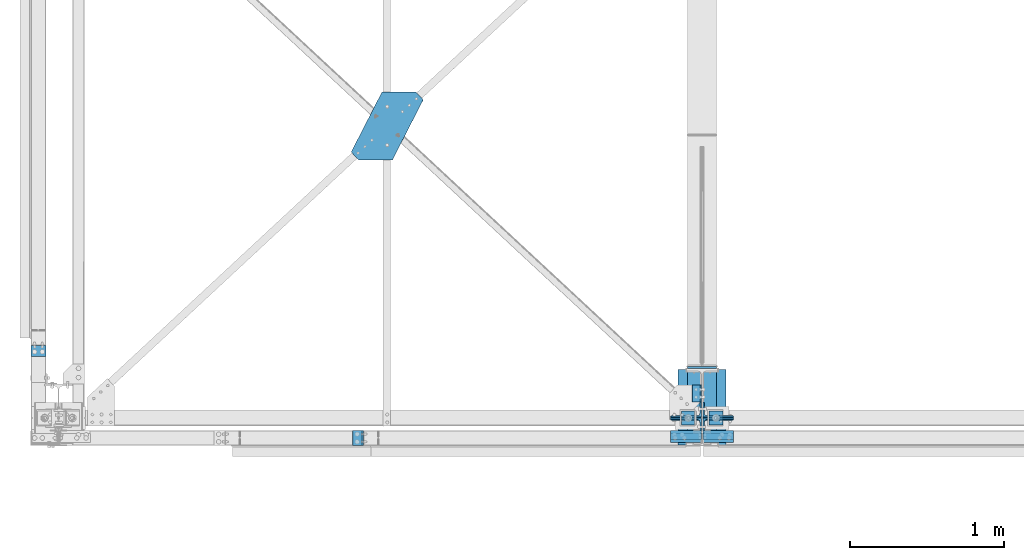
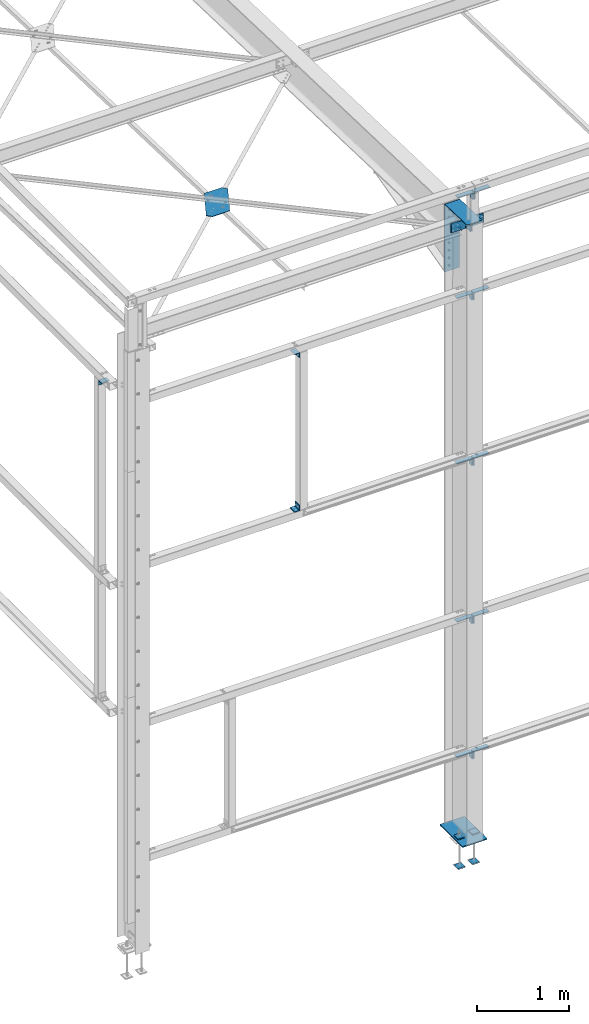
# One storey, part 62 of 496: 23 beams, 4 members, 23 elements without a shape of their own.
"""IFC2X3 building model written with IfcOpenShell, lengths in millimetres."""

import ifcopenshell
import ifcopenshell.guid

model = None  # the IFC model being written
_history = None  # IfcOwnerHistory: only IFC2X3 demands one
_inside = {}  # id of a spatial element -> (the spatial element, [elements in it])
_under = {}  # id of a project, library or spatial element -> (it, [spatial elements below it])
_declared = {}  # id of a project -> (the project, [libraries it declares])
_typed = {}  # id of a type object -> (the type object, [elements of that type])
_made_of = {}  # id of a material, layer set ... -> (it, [elements and type objects made of it])


def new_model(schema):
    """Start an empty IFC model of exactly this schema.

    Asked for "IFC4X3", IfcOpenShell would pick the latest addendum, in which some entities
    have other attributes; the version numbers below select the first issue.
    IFC2X3 requires an IfcOwnerHistory on every rooted entity: one is made here for all.
    """
    global model, _history
    if schema == "IFC4X3":
        model = ifcopenshell.file(schema_version=(4, 3, 0, 0))
    else:
        model = ifcopenshell.file(schema=schema)
    _inside.clear()
    _under.clear()
    _declared.clear()
    _typed.clear()
    _made_of.clear()
    _history = None
    if model.schema == "IFC2X3":
        org = make("IfcOrganization", Name="unknown")
        user = make(
            "IfcPersonAndOrganization",
            ThePerson=make("IfcPerson", FamilyName="unknown"),
            TheOrganization=org,
        )
        app = make(
            "IfcApplication",
            ApplicationDeveloper=org,
            Version="unknown",
            ApplicationFullName="unknown",
            ApplicationIdentifier="unknown",
        )
        _history = make(
            "IfcOwnerHistory",
            OwningUser=user,
            OwningApplication=app,
            ChangeAction="ADDED",
            CreationDate=0,
        )
    return model


def make(cls, **values):
    """One entity of the class cls with the attributes given. An attribute that is None is left unset."""
    return model.create_entity(
        cls, **{name: value for name, value in values.items() if value is not None}
    )


def rooted(cls, **values):
    """An entity with a GlobalId (a new one), such as an element, a storey or a relation."""
    return make(cls, GlobalId=ifcopenshell.guid.new(), OwnerHistory=_history, **values)


def si_unit(unit_type, name, prefix=None):
    """IfcSIUnit, for example si_unit("LENGTHUNIT", "METRE", prefix="MILLI")."""
    return make("IfcSIUnit", UnitType=unit_type, Prefix=prefix, Name=name)


def assignment(units):
    """IfcUnitAssignment: the units of a project."""
    return None if units is None else make("IfcUnitAssignment", Units=units)


def point(xyz):
    """IfcCartesianPoint."""
    return None if xyz is None else make("IfcCartesianPoint", Coordinates=xyz)


def direction(xyz):
    """IfcDirection."""
    return None if xyz is None else make("IfcDirection", DirectionRatios=xyz)


def frame(location, z_axis=None, x_axis=None):
    """IfcAxis2Placement3D, a coordinate frame: its origin and axes. An axis left out is left unset."""
    return make(
        "IfcAxis2Placement3D",
        Location=point(location),
        Axis=direction(z_axis),
        RefDirection=direction(x_axis),
    )


def frame_2d(location, x_axis=None):
    """IfcAxis2Placement2D, a coordinate frame in the plane: its origin and x axis."""
    return make(
        "IfcAxis2Placement2D", Location=point(location), RefDirection=direction(x_axis)
    )


def origin_with_axes():
    """The frame at (0, 0, 0) with the z axis (0, 0, 1) and the x axis (1, 0, 0) written out."""
    return frame((0.0, 0.0, 0.0), z_axis=(0.0, 0.0, 1.0), x_axis=(1.0, 0.0, 0.0))


def origin_2d_with_axis():
    """The frame at (0, 0) in the plane with the x axis (1, 0) written out."""
    return frame_2d((0.0, 0.0), x_axis=(1.0, 0.0))


def place(relative_to, where):
    """IfcLocalPlacement: puts the frame where relative to a parent placement (None: the world)."""
    return make(
        "IfcLocalPlacement", PlacementRelTo=relative_to, RelativePlacement=where
    )


def context(
    kind, dimensions, precision=None, world=None, true_north=None, identifier=None
):
    """IfcGeometricRepresentationContext, for example the 3D "Model" context."""
    return make(
        "IfcGeometricRepresentationContext",
        ContextIdentifier=identifier,
        ContextType=kind,
        CoordinateSpaceDimension=dimensions,
        Precision=precision,
        WorldCoordinateSystem=world,
        TrueNorth=true_north,
    )


def subcontext(parent, identifier, kind, view, scale=None):
    """IfcGeometricRepresentationSubContext, for example "Body" below "Model"."""
    return make(
        "IfcGeometricRepresentationSubContext",
        ContextIdentifier=identifier,
        ContextType=kind,
        ParentContext=parent,
        TargetScale=scale,
        TargetView=view,
    )


def project(units=None, contexts=None):
    """IfcProject with its units and contexts."""
    return rooted(
        "IfcProject",
        Name="project",
        RepresentationContexts=contexts,
        UnitsInContext=assignment(units),
    )


def spatial(cls, under=None, at=None, **own):
    """A site, building, storey or space (cls), placed at a placement, below another one or the project."""
    s = rooted(cls, ObjectPlacement=at, **own)
    if under is not None:
        _under.setdefault(under.id(), (under, []))[1].append(s)
    return s


def polyline(points):
    """IfcPolyline through the points."""
    return make("IfcPolyline", Points=[point(p) for p in points])


def profile(cls, at=None, kind="AREA", **sizes):
    """A parametric profile (cls). Its sizes go by their IFC names, for example OverallWidth=200.0."""
    return make(cls, ProfileType=kind, Position=at, **sizes)


def rectangle(**sizes):
    """IfcRectangleProfileDef."""
    return profile("IfcRectangleProfileDef", **sizes)


def l_section(**sizes):
    """IfcLShapeProfileDef."""
    return profile("IfcLShapeProfileDef", **sizes)


def outline(outer, holes=None, kind="AREA"):
    """IfcArbitraryClosedProfileDef: a profile drawn as a closed curve; with holes, ...WithVoids."""
    if holes is None:
        return make("IfcArbitraryClosedProfileDef", ProfileType=kind, OuterCurve=outer)
    return make(
        "IfcArbitraryProfileDefWithVoids",
        ProfileType=kind,
        OuterCurve=outer,
        InnerCurves=holes,
    )


def extrude(swept, where, along, depth):
    """IfcExtrudedAreaSolid: the profile swept, set in the frame where, extruded along a direction by depth."""
    return make(
        "IfcExtrudedAreaSolid",
        SweptArea=swept,
        Position=where,
        ExtrudedDirection=direction(along),
        Depth=depth,
    )


def shape(context_of_items, identifier, shape_type, items):
    """IfcShapeRepresentation: the items that make up one representation, for example the "Body"."""
    return make(
        "IfcShapeRepresentation",
        ContextOfItems=context_of_items,
        RepresentationIdentifier=identifier,
        RepresentationType=shape_type,
        Items=items,
    )


def material(Name=None, Category=None):
    """IfcMaterial."""
    return make("IfcMaterial", Name=Name, Category=Category)


def made_of(thing, what):
    """Note that an element or type object is made of a material, layer set ...; save() writes the relation."""
    if what is not None:
        _made_of.setdefault(what.id(), (what, []))[1].append(thing)
    return thing


def type_object(cls, material=None, **own):
    """A type object (cls), such as IfcWallType, which elements share."""
    return made_of(rooted(cls, **own), material)


def element(
    cls,
    number,
    at=None,
    inside=None,
    cuts=None,
    type_object=None,
    material=None,
    context=None,
    identifier="Body",
    shape_type=None,
    held_by="IfcProductDefinitionShape",
    body=None,
    shapes=None,
    **own,
):
    """One element of the class cls, such as IfcWall. Its Tag is "e" and its number.

    at: its placement. inside: the storey or other place that contains it. cuts: it is an
    opening in that element (IfcRelVoidsElement). A single representation is given by context,
    identifier, shape_type and body (its items); several are given by shapes. held_by: the class
    of the entity that holds the representations. save() writes the other relations.
    """
    e = rooted(cls, Tag="e%d" % number, ObjectPlacement=at, **own)
    if body is not None:
        shapes = [shape(context, identifier, shape_type, body)]
    if shapes is not None:
        e.Representation = make(held_by, Representations=shapes)
    if inside is not None:
        _inside.setdefault(inside.id(), (inside, []))[1].append(e)
    if cuts is not None:
        rooted(
            "IfcRelVoidsElement", RelatingBuildingElement=cuts, RelatedOpeningElement=e
        )
    if type_object is not None:
        _typed.setdefault(type_object.id(), (type_object, []))[1].append(e)
    return made_of(e, material)


def aggregate(whole, parts):
    """IfcRelAggregates: a whole, such as a stair, and the parts it consists of."""
    return rooted("IfcRelAggregates", RelatingObject=whole, RelatedObjects=parts)


def save(model, path):
    """Write the relations noted so far, then the file.

    IfcRelAggregates (storeys below a building ...), IfcRelContainedInSpatialStructure (elements
    in a storey), IfcRelDefinesByType, IfcRelAssociatesMaterial and IfcRelDeclares: one each for
    every whole, place, type object, material and project.
    """
    for whole, parts in _under.values():
        aggregate(whole, parts)
    for where, things in _inside.values():
        rooted(
            "IfcRelContainedInSpatialStructure",
            RelatedElements=things,
            RelatingStructure=where,
        )
    for kind, things in _typed.values():
        rooted("IfcRelDefinesByType", RelatedObjects=things, RelatingType=kind)
    for what, things in _made_of.values():
        rooted("IfcRelAssociatesMaterial", RelatedObjects=things, RelatingMaterial=what)
    for by, libraries in _declared.values():
        rooted("IfcRelDeclares", RelatingContext=by, RelatedDefinitions=libraries)
    model.write(path)


model = new_model("IFC2X3")

# Units and contexts
model_context = context("Model", 3, precision=1e-05, world=origin_with_axes())
body_context = subcontext(model_context, "Body", "Model", "MODEL_VIEW")
ifc_project = project(units=[si_unit("LENGTHUNIT", "METRE", prefix="MILLI"), si_unit("AREAUNIT", "SQUARE_METRE"), si_unit("VOLUMEUNIT", "CUBIC_METRE"), si_unit("MASSUNIT", "GRAM", prefix="KILO"), si_unit("TIMEUNIT", "SECOND"), si_unit("PLANEANGLEUNIT", "RADIAN"), si_unit("SOLIDANGLEUNIT", "STERADIAN"), si_unit("THERMODYNAMICTEMPERATUREUNIT", "DEGREE_CELSIUS"), si_unit("LUMINOUSINTENSITYUNIT", "LUMEN")], contexts=[model_context])

# Site, building, storey
site_placement = place(None, origin_with_axes())
site = spatial("IfcSite", under=ifc_project, at=site_placement, CompositionType="ELEMENT")
building_placement = place(site_placement, origin_with_axes())
building = spatial("IfcBuilding", under=site, at=building_placement, Name="Undefined", CompositionType="ELEMENT")
storey_placement = place(building_placement, origin_with_axes())
storey = spatial("IfcBuildingStorey", under=building, at=storey_placement, Name="Undefined", CompositionType="ELEMENT", Elevation=0.0)

# Assembly, beam
assembly_1_placement = place(storey_placement, origin_with_axes())
assembly_1 = element("IfcElementAssembly", 1, at=assembly_1_placement, inside=storey, Name="Steel Assembly", AssemblyPlace="NOTDEFINED", PredefinedType="RIGID_FRAME")
ifc_material_1 = material(Name="STEEL/S235 --------------")
beam_type_1 = type_object("IfcBeamType", PredefinedType="NOTDEFINED")
beam_1_placement = place(assembly_1_placement, frame((4144.89999331376, 103.610528224874, 7810.51283147873), z_axis=(0.0, -0.0324574240003861, -0.999473119011842), x_axis=(0.0, 0.999473119011842, -0.0324574240003861)))
beam_1 = element("IfcBeam", 2, at=beam_1_placement, type_object=beam_type_1, material=ifc_material_1, context=body_context, shape_type="SweptSolid", body=[
    extrude(l_section(Depth=60.0, Width=60.0, Thickness=5.0, FilletRadius=8.0, EdgeRadius=4.0, at=origin_2d_with_axis()), frame((109.9974094191, 0.0, 0.0), z_axis=(-1.0, 0.0, 0.0), x_axis=(0.0, -1.0, 0.0)), (0.0, 0.0, 1.0), 110.0),
])
aggregate(assembly_1, [beam_1])

assembly_2_placement = place(storey_placement, origin_with_axes())
assembly_2 = element("IfcElementAssembly", 3, at=assembly_2_placement, inside=storey, Name="Steel Assembly", AssemblyPlace="NOTDEFINED", PredefinedType="RIGID_FRAME")
beam_2_placement = place(assembly_2_placement, frame((4144.89999331368, 215.685506643728, 7872.94087723651), z_axis=(0.0, 0.0321995629880642, 0.999481459629631), x_axis=(0.0, -0.999481459629631, 0.0321995629880642)))
beam_2 = element("IfcBeam", 4, at=beam_2_placement, type_object=beam_type_1, material=ifc_material_1, context=body_context, shape_type="SweptSolid", body=[
    extrude(l_section(Depth=60.0, Width=60.0, Thickness=5.0, FilletRadius=8.0, EdgeRadius=4.0, at=origin_2d_with_axis()), frame((110.192402854577, 0.0, 7.64613392424516e-16), z_axis=(-1.0, 0.0, 0.0), x_axis=(0.0, -1.0, 0.0)), (0.0, 0.0, 1.0), 110.19),
])
aggregate(assembly_2, [beam_2])

assembly_3_placement = place(storey_placement, origin_with_axes())
assembly_3 = element("IfcElementAssembly", 5, at=assembly_3_placement, inside=storey, AssemblyPlace="NOTDEFINED", PredefinedType="NOTDEFINED")
ifc_material_2 = material(Name="Undefined/S235-E24")
beam_type_2 = type_object("IfcBeamType", PredefinedType="NOTDEFINED")
beam_3_placement = place(assembly_3_placement, frame((-179.999995944303, 434.993384638829, 7065.00000882637), z_axis=(0.0, -1.0, 0.0), x_axis=(1.0, 0.0, 0.0)))
beam_3 = element("IfcBeam", 6, at=beam_3_placement, type_object=beam_type_2, material=ifc_material_2, context=body_context, shape_type="SweptSolid", body=[
    extrude(l_section(Depth=70.0, Width=70.0, Thickness=7.0, FilletRadius=9.0, EdgeRadius=4.5, at=origin_2d_with_axis()), frame((100.000000000021, 5.72981662116945e-11, -4.09272615797818e-12), z_axis=(-1.0, 0.0, 0.0), x_axis=(0.0, -1.0, 0.0)), (0.0, 0.0, 1.0), 100.0),
])
aggregate(assembly_3, [beam_3])

assembly_4_placement = place(storey_placement, origin_with_axes())
assembly_4 = element("IfcElementAssembly", 7, at=assembly_4_placement, inside=storey, AssemblyPlace="NOTDEFINED", PredefinedType="NOTDEFINED")
beam_4_placement = place(assembly_4_placement, frame((1944.99476744318, -80.0000086005748, 5035.0), z_axis=(0.0, 0.0, 1.0), x_axis=(0.0, -1.0, 0.0)))
beam_4 = element("IfcBeam", 8, at=beam_4_placement, type_object=beam_type_2, material=ifc_material_2, context=body_context, shape_type="SweptSolid", body=[
    extrude(l_section(Depth=70.0, Width=70.0, Thickness=7.0, FilletRadius=9.0, EdgeRadius=4.5, at=origin_2d_with_axis()), frame((100.000000000021, 5.72981662116945e-11, -4.09272615797818e-12), z_axis=(-1.0, 0.0, 0.0), x_axis=(0.0, -1.0, 0.0)), (0.0, 0.0, 1.0), 100.0),
])
aggregate(assembly_4, [beam_4])

assembly_5_placement = place(storey_placement, origin_with_axes())
assembly_5 = element("IfcElementAssembly", 9, at=assembly_5_placement, inside=storey, AssemblyPlace="NOTDEFINED", PredefinedType="NOTDEFINED")
beam_5_placement = place(assembly_5_placement, frame((1944.99476844318, -180.000008614613, 7065.0), z_axis=(0.0, 0.0, -1.0), x_axis=(0.0, 1.0, 0.0)))
beam_5 = element("IfcBeam", 10, at=beam_5_placement, type_object=beam_type_2, material=ifc_material_2, context=body_context, shape_type="SweptSolid", body=[
    extrude(l_section(Depth=70.0, Width=70.0, Thickness=7.0, FilletRadius=9.0, EdgeRadius=4.5, at=origin_2d_with_axis()), frame((100.000000000021, 5.72981662116945e-11, -4.09272615797818e-12), z_axis=(-1.0, 0.0, 0.0), x_axis=(0.0, -1.0, 0.0)), (0.0, 0.0, 1.0), 100.0),
])
aggregate(assembly_5, [beam_5])

assembly_6_placement = place(storey_placement, origin_with_axes())
assembly_6 = element("IfcElementAssembly", 11, at=assembly_6_placement, inside=storey, AssemblyPlace="NOTDEFINED", PredefinedType="NOTDEFINED")
beam_type_3 = type_object("IfcBeamType", PredefinedType="NOTDEFINED")
beam_6_placement = place(assembly_6_placement, frame((2321.30220508621, 2117.62478728136, 7780.3566713165), z_axis=(0.0, 0.031410887010906, 0.999506556345274), x_axis=(-1.0, 0.0, 0.0)))
beam_6 = element("IfcBeam", 12, at=beam_6_placement, type_object=beam_type_3, material=ifc_material_2, context=body_context, shape_type="SweptSolid", body=[
    extrude(outline(polyline([(0.0, 0.0), (219.999999998594, -9.93168214336038e-10), (420.263031005037, 390.657226561482), (372.604370116365, 441.927673338805), (152.604415892733, 441.927612303649), (-47.6586227425214, 51.2704162588834), (0.0, 0.0)])), frame((0.0, 0.0, -3.0), z_axis=(0.0, 0.0, 1.0), x_axis=(1.0, 0.0, 0.0)), (0.0, 0.0, 1.0), 6.0),
])
aggregate(assembly_6, [beam_6])

# Assembly, member
assembly_7_placement = place(storey_placement, origin_with_axes())
assembly_7 = element("IfcElementAssembly", 13, at=assembly_7_placement, inside=storey, AssemblyPlace="NOTDEFINED", PredefinedType="NOTDEFINED")
member_type = type_object("IfcMemberType", PredefinedType="NOTDEFINED")
member_1_placement = place(assembly_7_placement, frame((4075.00000000072, 54.8594764916497, 8008.25789802935), z_axis=(-1.0, 0.0, 0.0), x_axis=(0.0, -0.031410887010906, -0.999506556345274)))
member_1 = element("IfcMember", 14, at=member_1_placement, type_object=member_type, material=ifc_material_2, context=body_context, shape_type="SweptSolid", body=[
    extrude(l_section(Depth=200.0, Width=100.0, Thickness=10.0, FilletRadius=15.0, EdgeRadius=7.5, at=origin_2d_with_axis()), frame((120.0, 0.0, 0.0), z_axis=(-1.0, 0.0, 0.0), x_axis=(0.0, -1.0, 0.0)), (0.0, 0.0, 1.0), 120.0),
])
aggregate(assembly_7, [member_1])

assembly_8_placement = place(storey_placement, origin_with_axes())
assembly_8 = element("IfcElementAssembly", 15, at=assembly_8_placement, inside=storey, AssemblyPlace="NOTDEFINED", PredefinedType="NOTDEFINED")
member_2_placement = place(assembly_8_placement, frame((4285.00000000005, 51.0901303241772, 7888.3171125173), z_axis=(1.0, 0.0, 0.0), x_axis=(0.0, 0.031410887010906, 0.999506556345274)))
member_2 = element("IfcMember", 16, at=member_2_placement, type_object=member_type, material=ifc_material_2, context=body_context, shape_type="SweptSolid", body=[
    extrude(l_section(Depth=200.0, Width=100.0, Thickness=10.0, FilletRadius=15.0, EdgeRadius=7.5, at=origin_2d_with_axis()), frame((120.0, 0.0, 0.0), z_axis=(-1.0, 0.0, 0.0), x_axis=(0.0, -1.0, 0.0)), (0.0, 0.0, 1.0), 120.0),
])
aggregate(assembly_8, [member_2])

assembly_9_placement = place(storey_placement, origin_with_axes())
assembly_9 = element("IfcElementAssembly", 17, at=assembly_9_placement, inside=storey, AssemblyPlace="NOTDEFINED", PredefinedType="NOTDEFINED")
member_3_placement = place(assembly_9_placement, frame((4075.00000000072, -54.8584254036496, 7891.64672871343), z_axis=(-1.0, 0.0, 0.0), x_axis=(0.0, 0.031410887010906, 0.999506556345274)))
member_3 = element("IfcMember", 18, at=member_3_placement, type_object=member_type, material=ifc_material_2, context=body_context, shape_type="SweptSolid", body=[
    extrude(l_section(Depth=200.0, Width=100.0, Thickness=10.0, FilletRadius=15.0, EdgeRadius=7.5, at=origin_2d_with_axis()), frame((120.0, 0.0, 0.0), z_axis=(-1.0, 0.0, 0.0), x_axis=(0.0, -1.0, 0.0)), (0.0, 0.0, 1.0), 120.0),
])
aggregate(assembly_9, [member_3])

assembly_10_placement = place(storey_placement, origin_with_axes())
assembly_10 = element("IfcElementAssembly", 19, at=assembly_10_placement, inside=storey, AssemblyPlace="NOTDEFINED", PredefinedType="NOTDEFINED")
member_4_placement = place(assembly_10_placement, frame((4285.00000000005, -51.0890792425898, 8011.58751422551), z_axis=(1.0, 0.0, 0.0), x_axis=(0.0, -0.031410887010906, -0.999506556345274)))
member_4 = element("IfcMember", 20, at=member_4_placement, type_object=member_type, material=ifc_material_2, context=body_context, shape_type="SweptSolid", body=[
    extrude(l_section(Depth=200.0, Width=100.0, Thickness=10.0, FilletRadius=15.0, EdgeRadius=7.5, at=origin_2d_with_axis()), frame((120.0, 0.0, 0.0), z_axis=(-1.0, 0.0, 0.0), x_axis=(0.0, -1.0, 0.0)), (0.0, 0.0, 1.0), 120.0),
])
aggregate(assembly_10, [member_4])

# Assembly, beam
assembly_11_placement = place(storey_placement, origin_with_axes())
assembly_11 = element("IfcElementAssembly", 21, at=assembly_11_placement, inside=storey, AssemblyPlace="NOTDEFINED", PredefinedType="NOTDEFINED")
beam_type_4 = type_object("IfcBeamType", PredefinedType="NOTDEFINED")
beam_7_placement = place(assembly_11_placement, frame((4075.00000320677, -100.00000666075, 8400.0), z_axis=(-1.0, 0.0, 0.0), x_axis=(0.0, -1.0, 0.0)))
beam_7 = element("IfcBeam", 22, at=beam_7_placement, type_object=beam_type_4, material=ifc_material_2, context=body_context, shape_type="SweptSolid", body=[
    extrude(l_section(Depth=200.0, Width=100.0, Thickness=10.0, FilletRadius=15.0, EdgeRadius=7.5, at=origin_2d_with_axis()), frame((60.0, 0.0, 0.0), z_axis=(-1.0, 0.0, 0.0), x_axis=(0.0, -1.0, 0.0)), (0.0, 0.0, 1.0), 60.0),
])
aggregate(assembly_11, [beam_7])

assembly_12_placement = place(storey_placement, origin_with_axes())
assembly_12 = element("IfcElementAssembly", 23, at=assembly_12_placement, inside=storey, AssemblyPlace="NOTDEFINED", PredefinedType="NOTDEFINED")
beam_8_placement = place(assembly_12_placement, frame((4285.00000308851, -160.000007080776, 8400.0), z_axis=(1.0, 0.0, 0.0), x_axis=(0.0, 1.0, 0.0)))
beam_8 = element("IfcBeam", 24, at=beam_8_placement, type_object=beam_type_4, material=ifc_material_2, context=body_context, shape_type="SweptSolid", body=[
    extrude(l_section(Depth=200.0, Width=100.0, Thickness=10.0, FilletRadius=15.0, EdgeRadius=7.5, at=origin_2d_with_axis()), frame((60.0, 0.0, 0.0), z_axis=(-1.0, 0.0, 0.0), x_axis=(0.0, -1.0, 0.0)), (0.0, 0.0, 1.0), 60.0),
])
aggregate(assembly_12, [beam_8])

assembly_13_placement = place(storey_placement, origin_with_axes())
assembly_13 = element("IfcElementAssembly", 25, at=assembly_13_placement, inside=storey, AssemblyPlace="NOTDEFINED", PredefinedType="NOTDEFINED")
beam_9_placement = place(assembly_13_placement, frame((4075.0000032068, -80.000006660929, 950.0), z_axis=(-1.0, 0.0, 0.0), x_axis=(0.0, -1.0, 0.0)))
beam_9 = element("IfcBeam", 26, at=beam_9_placement, type_object=beam_type_4, material=ifc_material_2, context=body_context, shape_type="SweptSolid", body=[
    extrude(l_section(Depth=200.0, Width=100.0, Thickness=10.0, FilletRadius=15.0, EdgeRadius=7.5, at=origin_2d_with_axis()), frame((60.0, 0.0, 0.0), z_axis=(-1.0, 0.0, 0.0), x_axis=(0.0, -1.0, 0.0)), (0.0, 0.0, 1.0), 60.0),
])
aggregate(assembly_13, [beam_9])

assembly_14_placement = place(storey_placement, origin_with_axes())
assembly_14 = element("IfcElementAssembly", 27, at=assembly_14_placement, inside=storey, AssemblyPlace="NOTDEFINED", PredefinedType="NOTDEFINED")
beam_10_placement = place(assembly_14_placement, frame((4285.00000308669, -140.000007080964, 950.0), z_axis=(1.0, 0.0, 0.0), x_axis=(0.0, 1.0, 0.0)))
beam_10 = element("IfcBeam", 28, at=beam_10_placement, type_object=beam_type_4, material=ifc_material_2, context=body_context, shape_type="SweptSolid", body=[
    extrude(l_section(Depth=200.0, Width=100.0, Thickness=10.0, FilletRadius=15.0, EdgeRadius=7.5, at=origin_2d_with_axis()), frame((60.0, 0.0, 0.0), z_axis=(-1.0, 0.0, 0.0), x_axis=(0.0, -1.0, 0.0)), (0.0, 0.0, 1.0), 60.0),
])
aggregate(assembly_14, [beam_10])

assembly_15_placement = place(storey_placement, origin_with_axes())
assembly_15 = element("IfcElementAssembly", 29, at=assembly_15_placement, inside=storey, AssemblyPlace="NOTDEFINED", PredefinedType="NOTDEFINED")
beam_11_placement = place(assembly_15_placement, frame((4075.0000032068, -80.000006660929, 2750.0), z_axis=(-1.0, 0.0, 0.0), x_axis=(0.0, -1.0, 0.0)))
beam_11 = element("IfcBeam", 30, at=beam_11_placement, type_object=beam_type_4, material=ifc_material_2, context=body_context, shape_type="SweptSolid", body=[
    extrude(l_section(Depth=200.0, Width=100.0, Thickness=10.0, FilletRadius=15.0, EdgeRadius=7.5, at=origin_2d_with_axis()), frame((60.0, 0.0, 0.0), z_axis=(-1.0, 0.0, 0.0), x_axis=(0.0, -1.0, 0.0)), (0.0, 0.0, 1.0), 60.0),
])
aggregate(assembly_15, [beam_11])

assembly_16_placement = place(storey_placement, origin_with_axes())
assembly_16 = element("IfcElementAssembly", 31, at=assembly_16_placement, inside=storey, AssemblyPlace="NOTDEFINED", PredefinedType="NOTDEFINED")
beam_12_placement = place(assembly_16_placement, frame((4285.00000308669, -140.000007080964, 2750.0), z_axis=(1.0, 0.0, 0.0), x_axis=(0.0, 1.0, 0.0)))
beam_12 = element("IfcBeam", 32, at=beam_12_placement, type_object=beam_type_4, material=ifc_material_2, context=body_context, shape_type="SweptSolid", body=[
    extrude(l_section(Depth=200.0, Width=100.0, Thickness=10.0, FilletRadius=15.0, EdgeRadius=7.5, at=origin_2d_with_axis()), frame((60.0, 0.0, 0.0), z_axis=(-1.0, 0.0, 0.0), x_axis=(0.0, -1.0, 0.0)), (0.0, 0.0, 1.0), 60.0),
])
aggregate(assembly_16, [beam_12])

assembly_17_placement = place(storey_placement, origin_with_axes())
assembly_17 = element("IfcElementAssembly", 33, at=assembly_17_placement, inside=storey, AssemblyPlace="NOTDEFINED", PredefinedType="NOTDEFINED")
beam_13_placement = place(assembly_17_placement, frame((4075.0000032068, -80.000006660929, 4850.0), z_axis=(-1.0, 0.0, 0.0), x_axis=(0.0, -1.0, 0.0)))
beam_13 = element("IfcBeam", 34, at=beam_13_placement, type_object=beam_type_4, material=ifc_material_2, context=body_context, shape_type="SweptSolid", body=[
    extrude(l_section(Depth=200.0, Width=100.0, Thickness=10.0, FilletRadius=15.0, EdgeRadius=7.5, at=origin_2d_with_axis()), frame((60.0, 0.0, 0.0), z_axis=(-1.0, 0.0, 0.0), x_axis=(0.0, -1.0, 0.0)), (0.0, 0.0, 1.0), 60.0),
])
aggregate(assembly_17, [beam_13])

assembly_18_placement = place(storey_placement, origin_with_axes())
assembly_18 = element("IfcElementAssembly", 35, at=assembly_18_placement, inside=storey, AssemblyPlace="NOTDEFINED", PredefinedType="NOTDEFINED")
beam_14_placement = place(assembly_18_placement, frame((4285.00000308669, -140.000007080964, 4850.0), z_axis=(1.0, 0.0, 0.0), x_axis=(0.0, 1.0, 0.0)))
beam_14 = element("IfcBeam", 36, at=beam_14_placement, type_object=beam_type_4, material=ifc_material_2, context=body_context, shape_type="SweptSolid", body=[
    extrude(l_section(Depth=200.0, Width=100.0, Thickness=10.0, FilletRadius=15.0, EdgeRadius=7.5, at=origin_2d_with_axis()), frame((60.0, 0.0, 0.0), z_axis=(-1.0, 0.0, 0.0), x_axis=(0.0, -1.0, 0.0)), (0.0, 0.0, 1.0), 60.0),
])
aggregate(assembly_18, [beam_14])

assembly_19_placement = place(storey_placement, origin_with_axes())
assembly_19 = element("IfcElementAssembly", 37, at=assembly_19_placement, inside=storey, AssemblyPlace="NOTDEFINED", PredefinedType="NOTDEFINED")
beam_15_placement = place(assembly_19_placement, frame((4075.0000032068, -80.000006660929, 7050.0), z_axis=(-1.0, 0.0, 0.0), x_axis=(0.0, -1.0, 0.0)))
beam_15 = element("IfcBeam", 38, at=beam_15_placement, type_object=beam_type_4, material=ifc_material_2, context=body_context, shape_type="SweptSolid", body=[
    extrude(l_section(Depth=200.0, Width=100.0, Thickness=10.0, FilletRadius=15.0, EdgeRadius=7.5, at=origin_2d_with_axis()), frame((60.0, 0.0, 0.0), z_axis=(-1.0, 0.0, 0.0), x_axis=(0.0, -1.0, 0.0)), (0.0, 0.0, 1.0), 60.0),
])
aggregate(assembly_19, [beam_15])

assembly_20_placement = place(storey_placement, origin_with_axes())
assembly_20 = element("IfcElementAssembly", 39, at=assembly_20_placement, inside=storey, AssemblyPlace="NOTDEFINED", PredefinedType="NOTDEFINED")
beam_16_placement = place(assembly_20_placement, frame((4285.00000308669, -140.000007080964, 7050.0), z_axis=(1.0, 0.0, 0.0), x_axis=(0.0, 1.0, 0.0)))
beam_16 = element("IfcBeam", 40, at=beam_16_placement, type_object=beam_type_4, material=ifc_material_2, context=body_context, shape_type="SweptSolid", body=[
    extrude(l_section(Depth=200.0, Width=100.0, Thickness=10.0, FilletRadius=15.0, EdgeRadius=7.5, at=origin_2d_with_axis()), frame((60.0, 0.0, 0.0), z_axis=(-1.0, 0.0, 0.0), x_axis=(0.0, -1.0, 0.0)), (0.0, 0.0, 1.0), 60.0),
])
aggregate(assembly_20, [beam_16])

assembly_21_placement = place(storey_placement, origin_with_axes())
assembly_21 = element("IfcElementAssembly", 41, at=assembly_21_placement, inside=storey, Name="TRAVERSE", AssemblyPlace="NOTDEFINED", PredefinedType="NOTDEFINED")
beam_type_5 = type_object("IfcBeamType", PredefinedType="NOTDEFINED")
beam_17_placement = place(assembly_21_placement, frame((4180.0, 327.5, 8029.93865805382), z_axis=(1.0, 0.0, 0.0), x_axis=(0.0, 0.0, -1.0)))
beam_17 = element("IfcBeam", 42, at=beam_17_placement, type_object=beam_type_5, material=ifc_material_2, context=body_context, shape_type="SweptSolid", body=[
    extrude(rectangle(XDim=15.0, YDim=190.0, at=origin_2d_with_axis()), frame((900.000000001432, 9.99200722164227e-14, 0.0), z_axis=(-1.0, 0.0, 0.0), x_axis=(0.0, -1.0, 0.0)), (0.0, 0.0, 1.0), 900.0),
])
aggregate(assembly_21, [beam_17])

# Assembly, beams
assembly_22_placement = place(storey_placement, origin_with_axes())
assembly_22 = element("IfcElementAssembly", 43, at=assembly_22_placement, inside=storey, Name="POTEAU", AssemblyPlace="NOTDEFINED", PredefinedType="NOTDEFINED")
beam_type_6 = type_object("IfcBeamType", PredefinedType="NOTDEFINED")
beam_18_placement = place(assembly_22_placement, frame((4180.0000000032, 312.157053789367, 8035.18760098347), z_axis=(-1.0, 0.0, 0.0), x_axis=(0.0, -0.999506556345276, 0.031410887010852)))
beam_18 = element("IfcBeam", 44, at=beam_18_placement, type_object=beam_type_6, material=ifc_material_2, context=body_context, shape_type="SweptSolid", body=[
    extrude(rectangle(XDim=10.0, YDim=190.0, at=origin_2d_with_axis()), frame((484.238942680055, 0.0, 0.0), z_axis=(-1.0, 0.0, 0.0), x_axis=(0.0, -1.0, 0.0)), (0.0, 0.0, 1.0), 484.24),
])
beam_type_7 = type_object("IfcBeamType", PredefinedType="NOTDEFINED")
beam_19_placement = place(assembly_22_placement, frame((4334.99715044471, 70.0, -192.5), z_axis=(0.0, -1.0, 0.0), x_axis=(-1.0, 0.0, 0.0)))
beam_19 = element("IfcBeam", 45, at=beam_19_placement, type_object=beam_type_7, material=ifc_material_2, context=body_context, shape_type="SweptSolid", body=[
    extrude(rectangle(XDim=15.0, YDim=490.0, at=origin_2d_with_axis()), frame((310.0, 0.0, 0.0), z_axis=(-1.0, 0.0, 0.0), x_axis=(0.0, -1.0, 0.0)), (0.0, 0.0, 1.0), 310.0),
])
aggregate(assembly_22, [beam_18, beam_19])

assembly_23_placement = place(storey_placement, origin_with_axes())
assembly_23 = element("IfcElementAssembly", 46, at=assembly_23_placement, inside=storey, Name="PS24", AssemblyPlace="NOTDEFINED", PredefinedType="NOTDEFINED")
beam_type_8 = type_object("IfcBeamType", PredefinedType="NOTDEFINED")
beam_20_placement = place(assembly_23_placement, frame((4134.99715044471, -45.0, -177.5), z_axis=(0.0, 0.0, 1.0), x_axis=(0.0, 1.0, 0.0)))
beam_20 = element("IfcBeam", 47, at=beam_20_placement, type_object=beam_type_8, material=ifc_material_2, context=body_context, shape_type="SweptSolid", body=[
    extrude(outline(polyline([(0.0, 0.0), (90.0, 0.0), (90.0, 90.0), (0.0, 90.0), (0.0, 0.0)])), frame((0.0, 0.0, -7.5), z_axis=(0.0, 0.0, 1.0), x_axis=(1.0, 0.0, 0.0)), (0.0, 0.0, 1.0), 15.0),
])
beam_21_placement = place(assembly_23_placement, frame((4314.99715044471, -45.0, -177.5), z_axis=(0.0, 0.0, 1.0), x_axis=(0.0, 1.0, 0.0)))
beam_21 = element("IfcBeam", 48, at=beam_21_placement, type_object=beam_type_8, material=ifc_material_2, context=body_context, shape_type="SweptSolid", body=[
    extrude(outline(polyline([(0.0, 0.0), (90.0, 0.0), (90.0, 90.0), (0.0, 90.0), (0.0, 0.0)])), frame((0.0, 0.0, -7.5), z_axis=(0.0, 0.0, 1.0), x_axis=(1.0, 0.0, 0.0)), (0.0, 0.0, 1.0), 15.0),
])
beam_22_placement = place(assembly_23_placement, frame((4134.99715044471, -45.0, -572.5), z_axis=(0.0, 0.0, 1.0), x_axis=(0.0, 1.0, 0.0)))
beam_22 = element("IfcBeam", 49, at=beam_22_placement, type_object=beam_type_8, material=ifc_material_2, context=body_context, shape_type="SweptSolid", body=[
    extrude(outline(polyline([(0.0, 0.0), (90.0, 0.0), (90.0, 90.0), (0.0, 90.0), (0.0, 0.0)])), frame((0.0, 0.0, -7.5), z_axis=(0.0, 0.0, 1.0), x_axis=(1.0, 0.0, 0.0)), (0.0, 0.0, 1.0), 15.0),
])
beam_23_placement = place(assembly_23_placement, frame((4314.99715044471, -45.0, -572.5), z_axis=(0.0, 0.0, 1.0), x_axis=(0.0, 1.0, 0.0)))
beam_23 = element("IfcBeam", 50, at=beam_23_placement, type_object=beam_type_8, material=ifc_material_2, context=body_context, shape_type="SweptSolid", body=[
    extrude(outline(polyline([(0.0, 0.0), (90.0, 0.0), (90.0, 90.0), (0.0, 90.0), (0.0, 0.0)])), frame((0.0, 0.0, -7.5), z_axis=(0.0, 0.0, 1.0), x_axis=(1.0, 0.0, 0.0)), (0.0, 0.0, 1.0), 15.0),
])
aggregate(assembly_23, [beam_20, beam_21, beam_22, beam_23])

save(model, "model.ifc")
